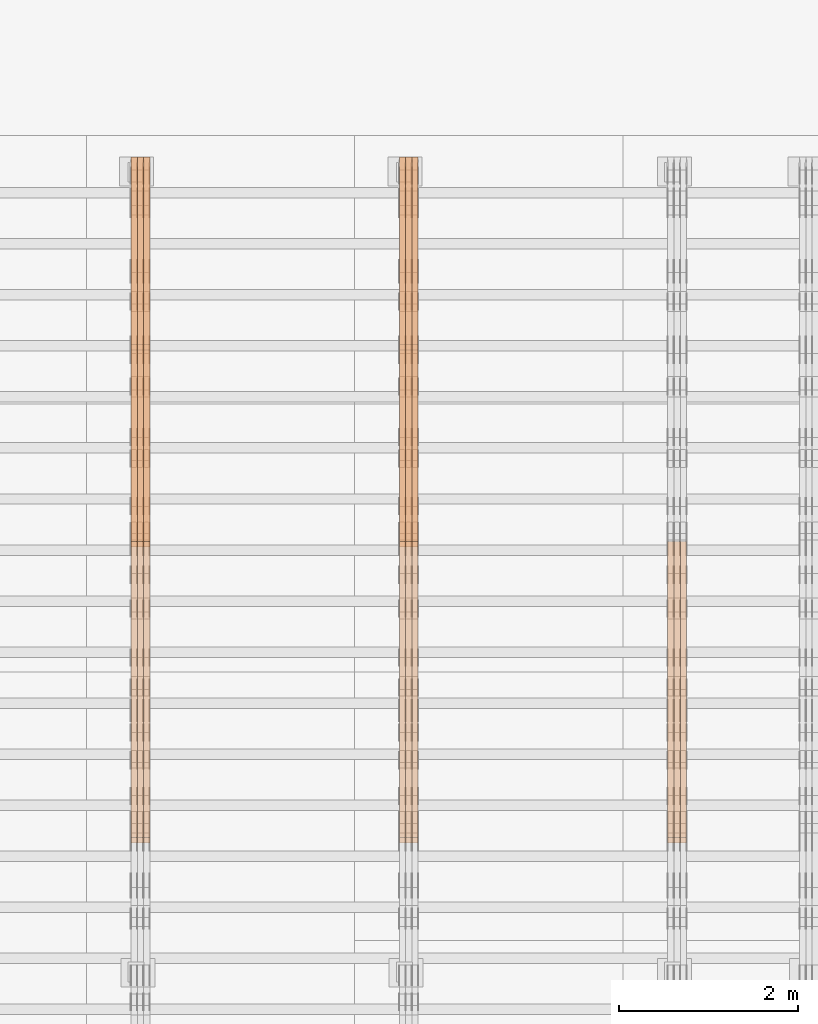
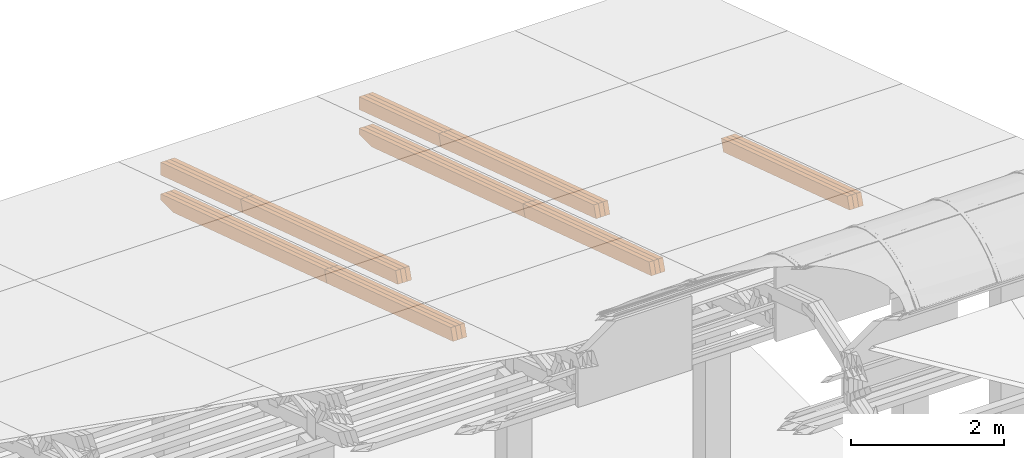
# One storey, part 31 of 385: 27 proxies.
"""IFC2X3 building model written with IfcOpenShell, lengths in millimetres."""

from ifc_helpers import new_model, entity, si_unit, converted_unit, derived_unit, direction, frame, origin, place, context, subcontext, project, spatial, polyline, outline, extrude, source, transform, mapped, material, type_object, type_shapes, element, save


model = new_model("IFC2X3")

# Units and contexts
model_context = context("Model", 3, precision=0.01, world=origin(), true_north=direction((6.12303176911189e-17, 1.0)))
body_context = subcontext(model_context, "Body", "Model", "MODEL_VIEW")
ifc_project = project(units=[si_unit("LENGTHUNIT", "METRE", prefix="MILLI"), si_unit("AREAUNIT", "SQUARE_METRE"), si_unit("VOLUMEUNIT", "CUBIC_METRE"), converted_unit("PLANEANGLEUNIT", "DEGREE", entity("IfcRatioMeasure", 0.0174532925199433), si_unit("PLANEANGLEUNIT", "RADIAN"), dimensions=[0, 0, 0, 0, 0, 0, 0]), si_unit("MASSUNIT", "GRAM", prefix="KILO"), derived_unit("MASSDENSITYUNIT", [(si_unit("MASSUNIT", "GRAM", prefix="KILO"), 1), (si_unit("LENGTHUNIT", "METRE"), -3)]), si_unit("TIMEUNIT", "SECOND"), si_unit("FREQUENCYUNIT", "HERTZ"), si_unit("THERMODYNAMICTEMPERATUREUNIT", "DEGREE_CELSIUS"), derived_unit("THERMALTRANSMITTANCEUNIT", [(si_unit("MASSUNIT", "GRAM", prefix="KILO"), 1), (si_unit("THERMODYNAMICTEMPERATUREUNIT", "KELVIN"), -1), (si_unit("TIMEUNIT", "SECOND"), -3)]), derived_unit("VOLUMETRICFLOWRATEUNIT", [(si_unit("LENGTHUNIT", "METRE"), 3), (si_unit("TIMEUNIT", "SECOND"), -1)]), si_unit("ELECTRICCURRENTUNIT", "AMPERE"), si_unit("ELECTRICVOLTAGEUNIT", "VOLT"), si_unit("POWERUNIT", "WATT"), si_unit("FORCEUNIT", "NEWTON", prefix="KILO"), si_unit("ILLUMINANCEUNIT", "LUX"), si_unit("LUMINOUSFLUXUNIT", "LUMEN"), si_unit("LUMINOUSINTENSITYUNIT", "CANDELA"), derived_unit("USERDEFINED", [(si_unit("MASSUNIT", "GRAM", prefix="KILO"), -1), (si_unit("LENGTHUNIT", "METRE"), -2), (si_unit("TIMEUNIT", "SECOND"), 3), (si_unit("LUMINOUSFLUXUNIT", "LUMEN"), 1)]), derived_unit("LINEARVELOCITYUNIT", [(si_unit("LENGTHUNIT", "METRE"), 1), (si_unit("TIMEUNIT", "SECOND"), -1)]), si_unit("PRESSUREUNIT", "PASCAL"), derived_unit("USERDEFINED", [(si_unit("LENGTHUNIT", "METRE"), -2), (si_unit("MASSUNIT", "GRAM", prefix="KILO"), 1), (si_unit("TIMEUNIT", "SECOND"), -2)])], contexts=[model_context])

# Site, building, storey
site_placement = place(None, origin())
site = spatial("IfcSite", under=ifc_project, at=site_placement, CompositionType="ELEMENT")
building_placement = place(site_placement, origin())
building = spatial("IfcBuilding", under=site, at=building_placement, CompositionType="ELEMENT")
storey_placement = place(building_placement, origin())
storey = spatial("IfcBuildingStorey", under=building, at=storey_placement, Name="Default", CompositionType="ELEMENT", Elevation=0.0)

# Proxies
ifc_material_1 = material(Name="IfcSurfaceStyle #557706")
building_element_proxy_type_1 = type_object("IfcBuildingElementProxyType", Name="T1-B2 557704", PredefinedType="NOTDEFINED", material=ifc_material_1)
shared_shape_1 = source(origin(), body_context, "Body", "SweptSolid", [
    extrude(outline(polyline([(-1738.61933402934, -97.4999466901035), (1738.6190788485, -97.4999466901035), (1738.6191018378, 97.4999466901035), (-1738.61884665697, 97.4999466901035), (-1738.61933402934, -97.4999466901035)])), frame((1738.6191018378, 97.4999528847471, 0.0), z_axis=(0.0, 0.0, 1.0), x_axis=(-1.0, 0.0, 0.0)), (0.0, 0.0, 1.0), 69.9999999999998),
])
type_shapes(building_element_proxy_type_1, [shared_shape_1])
proxy_1_placement = place(building_placement, frame((48385.0, 22140.4521465233, 1306.03026754604), z_axis=(-1.0, 0.0, 0.0), x_axis=(0.0, -0.951056516295124, 0.309016994375039)))
element("IfcBuildingElementProxy", 1, at=proxy_1_placement, inside=storey, type_object=building_element_proxy_type_1, material=ifc_material_1, Name="T1-B2", context=body_context, shape_type="MappedRepresentation", body=[
    mapped(shared_shape_1, transform((0.0, 0.0, 0.0), scale=1.0)),
])
ifc_material_2 = material(Name="IfcSurfaceStyle #557649")
building_element_proxy_type_2 = type_object("IfcBuildingElementProxyType", Name="T1-B2 557647", PredefinedType="NOTDEFINED", material=ifc_material_2)
shared_shape_2 = source(origin(), body_context, "Body", "SweptSolid", [
    extrude(outline(polyline([(-1738.61933402934, -97.4999466901035), (1738.6190788485, -97.4999466901035), (1738.6191018378, 97.4999466901035), (-1738.61884665697, 97.4999466901035), (-1738.61933402934, -97.4999466901035)])), frame((1738.6191018378, 97.4999528847471, 0.0), z_axis=(0.0, 0.0, 1.0), x_axis=(-1.0, 0.0, 0.0)), (0.0, 0.0, 1.0), 69.9999999999998),
])
type_shapes(building_element_proxy_type_2, [shared_shape_2])
proxy_2_placement = place(building_placement, frame((48315.0, 22140.4521465233, 1306.03026754604), z_axis=(-1.0, 0.0, 0.0), x_axis=(0.0, -0.951056516295124, 0.309016994375039)))
element("IfcBuildingElementProxy", 2, at=proxy_2_placement, inside=storey, type_object=building_element_proxy_type_2, material=ifc_material_2, Name="T1-B2", context=body_context, shape_type="MappedRepresentation", body=[
    mapped(shared_shape_2, transform((0.0, 0.0, 0.0), scale=1.0)),
])
ifc_material_3 = material(Name="IfcSurfaceStyle #557592")
building_element_proxy_type_3 = type_object("IfcBuildingElementProxyType", Name="T1-B2 557590", PredefinedType="NOTDEFINED", material=ifc_material_3)
shared_shape_3 = source(origin(), body_context, "Body", "SweptSolid", [
    extrude(outline(polyline([(-1738.61933402934, -97.4999466901035), (1738.6190788485, -97.4999466901035), (1738.6191018378, 97.4999466901035), (-1738.61884665697, 97.4999466901035), (-1738.61933402934, -97.4999466901035)])), frame((1738.6191018378, 97.4999528847471, 0.0), z_axis=(0.0, 0.0, 1.0), x_axis=(-1.0, 0.0, 0.0)), (0.0, 0.0, 1.0), 69.9999999999998),
])
type_shapes(building_element_proxy_type_3, [shared_shape_3])
proxy_3_placement = place(building_placement, frame((48245.0, 22140.4521465233, 1306.03026754604), z_axis=(-1.0, 0.0, 0.0), x_axis=(0.0, -0.951056516295124, 0.309016994375039)))
element("IfcBuildingElementProxy", 3, at=proxy_3_placement, inside=storey, type_object=building_element_proxy_type_3, material=ifc_material_3, Name="T1-B2", context=body_context, shape_type="MappedRepresentation", body=[
    mapped(shared_shape_3, transform((0.0, 0.0, 0.0), scale=1.0)),
])
ifc_material_4 = material(Name="IfcSurfaceStyle #524669")
building_element_proxy_type_4 = type_object("IfcBuildingElementProxyType", Name="T1-T2 524667", PredefinedType="NOTDEFINED", material=ifc_material_4)
shared_shape_4 = source(origin(), body_context, "Body", "SweptSolid", [
    extrude(outline(polyline([(-2137.04373183812, -97.5000250291418), (2137.04394104036, -97.5000250291418), (2137.04396402965, 97.5000250291418), (-2137.04417323189, 97.5000250291418), (-2137.04373183812, -97.5000250291418)])), frame((2137.04396402965, 97.5001541485632, 0.0), z_axis=(0.0, 0.0, 1.0), x_axis=(-1.0, 0.0, 0.0)), (0.0, 0.0, 1.0), 69.9999999999997),
])
type_shapes(building_element_proxy_type_4, [shared_shape_4])
proxy_4_placement = place(building_placement, frame((45385.0, 24344.7841397874, 1095.2368156767), z_axis=(-1.0, 0.0, 0.0), x_axis=(0.0, -0.951056516295154, 0.309016994374948)))
element("IfcBuildingElementProxy", 4, at=proxy_4_placement, inside=storey, type_object=building_element_proxy_type_4, material=ifc_material_4, Name="T1-T2", context=body_context, shape_type="MappedRepresentation", body=[
    mapped(shared_shape_4, transform((0.0, 0.0, 0.0), scale=1.0)),
])
ifc_material_5 = material(Name="IfcSurfaceStyle #524612")
building_element_proxy_type_5 = type_object("IfcBuildingElementProxyType", Name="T1-T2 524610", PredefinedType="NOTDEFINED", material=ifc_material_5)
shared_shape_5 = source(origin(), body_context, "Body", "SweptSolid", [
    extrude(outline(polyline([(-2137.04373183812, -97.5000250291418), (2137.04394104036, -97.5000250291418), (2137.04396402965, 97.5000250291418), (-2137.04417323189, 97.5000250291418), (-2137.04373183812, -97.5000250291418)])), frame((2137.04396402965, 97.5001541485632, 0.0), z_axis=(0.0, 0.0, 1.0), x_axis=(-1.0, 0.0, 0.0)), (0.0, 0.0, 1.0), 69.9999999999997),
])
type_shapes(building_element_proxy_type_5, [shared_shape_5])
proxy_5_placement = place(building_placement, frame((45315.0, 24344.7841397874, 1095.2368156767), z_axis=(-1.0, 0.0, 0.0), x_axis=(0.0, -0.951056516295154, 0.309016994374948)))
element("IfcBuildingElementProxy", 5, at=proxy_5_placement, inside=storey, type_object=building_element_proxy_type_5, material=ifc_material_5, Name="T1-T2", context=body_context, shape_type="MappedRepresentation", body=[
    mapped(shared_shape_5, transform((0.0, 0.0, 0.0), scale=1.0)),
])
ifc_material_6 = material(Name="IfcSurfaceStyle #524555")
building_element_proxy_type_6 = type_object("IfcBuildingElementProxyType", Name="T1-T2 524553", PredefinedType="NOTDEFINED", material=ifc_material_6)
shared_shape_6 = source(origin(), body_context, "Body", "SweptSolid", [
    extrude(outline(polyline([(-2137.04373183812, -97.5000250291418), (2137.04394104036, -97.5000250291418), (2137.04396402965, 97.5000250291418), (-2137.04417323189, 97.5000250291418), (-2137.04373183812, -97.5000250291418)])), frame((2137.04396402965, 97.5001541485632, 0.0), z_axis=(0.0, 0.0, 1.0), x_axis=(-1.0, 0.0, 0.0)), (0.0, 0.0, 1.0), 69.9999999999997),
])
type_shapes(building_element_proxy_type_6, [shared_shape_6])
proxy_6_placement = place(building_placement, frame((45245.0, 24344.7841397874, 1095.2368156767), z_axis=(-1.0, 0.0, 0.0), x_axis=(0.0, -0.951056516295154, 0.309016994374948)))
element("IfcBuildingElementProxy", 6, at=proxy_6_placement, inside=storey, type_object=building_element_proxy_type_6, material=ifc_material_6, Name="T1-T2", context=body_context, shape_type="MappedRepresentation", body=[
    mapped(shared_shape_6, transform((0.0, 0.0, 0.0), scale=1.0)),
])
ifc_material_7 = material(Name="IfcSurfaceStyle #524498")
building_element_proxy_type_7 = type_object("IfcBuildingElementProxyType", Name="T1-T3 524496", PredefinedType="NOTDEFINED", material=ifc_material_7)
shared_shape_7 = source(origin(), body_context, "Body", "SweptSolid", [
    extrude(outline(polyline([(-1117.22419189679, -97.5000115568039), (1085.54451125458, -97.5000115568039), (1148.90384954971, 97.5000115568039), (-1117.2241689075, 97.5000115568039), (-1117.22419189679, -97.5000115568039)])), frame((1148.90385201956, 97.5000191595882, 0.0), z_axis=(0.0, 0.0, 1.0), x_axis=(-1.0, 0.0, 0.0)), (0.0, 0.0, 1.0), 69.9999999999999),
])
type_shapes(building_element_proxy_type_7, [shared_shape_7])
proxy_7_placement = place(building_placement, frame((45385.0, 26500.0, 394.964866273674), z_axis=(-1.0, 0.0, 0.0), x_axis=(0.0, -0.951056516295154, 0.309016994374948)))
element("IfcBuildingElementProxy", 7, at=proxy_7_placement, inside=storey, type_object=building_element_proxy_type_7, material=ifc_material_7, Name="T1-T3", context=body_context, shape_type="MappedRepresentation", body=[
    mapped(shared_shape_7, transform((0.0, 0.0, 0.0), scale=1.0)),
])
ifc_material_8 = material(Name="IfcSurfaceStyle #524441")
building_element_proxy_type_8 = type_object("IfcBuildingElementProxyType", Name="T1-T3 524439", PredefinedType="NOTDEFINED", material=ifc_material_8)
shared_shape_8 = source(origin(), body_context, "Body", "SweptSolid", [
    extrude(outline(polyline([(-1117.22419189679, -97.5000115568039), (1085.54451125458, -97.5000115568039), (1148.90384954971, 97.5000115568039), (-1117.2241689075, 97.5000115568039), (-1117.22419189679, -97.5000115568039)])), frame((1148.90385201956, 97.5000191595882, 0.0), z_axis=(0.0, 0.0, 1.0), x_axis=(-1.0, 0.0, 0.0)), (0.0, 0.0, 1.0), 69.9999999999999),
])
type_shapes(building_element_proxy_type_8, [shared_shape_8])
proxy_8_placement = place(building_placement, frame((45315.0, 26500.0, 394.964866273674), z_axis=(-1.0, 0.0, 0.0), x_axis=(0.0, -0.951056516295154, 0.309016994374948)))
element("IfcBuildingElementProxy", 8, at=proxy_8_placement, inside=storey, type_object=building_element_proxy_type_8, material=ifc_material_8, Name="T1-T3", context=body_context, shape_type="MappedRepresentation", body=[
    mapped(shared_shape_8, transform((0.0, 0.0, 0.0), scale=1.0)),
])
ifc_material_9 = material(Name="IfcSurfaceStyle #524384")
building_element_proxy_type_9 = type_object("IfcBuildingElementProxyType", Name="T1-T3 524382", PredefinedType="NOTDEFINED", material=ifc_material_9)
shared_shape_9 = source(origin(), body_context, "Body", "SweptSolid", [
    extrude(outline(polyline([(-1117.22419189679, -97.5000115568039), (1085.54451125458, -97.5000115568039), (1148.90384954971, 97.5000115568039), (-1117.2241689075, 97.5000115568039), (-1117.22419189679, -97.5000115568039)])), frame((1148.90385201956, 97.5000191595882, 0.0), z_axis=(0.0, 0.0, 1.0), x_axis=(-1.0, 0.0, 0.0)), (0.0, 0.0, 1.0), 69.9999999999999),
])
type_shapes(building_element_proxy_type_9, [shared_shape_9])
proxy_9_placement = place(building_placement, frame((45245.0, 26500.0, 394.964866273674), z_axis=(-1.0, 0.0, 0.0), x_axis=(0.0, -0.951056516295154, 0.309016994374948)))
element("IfcBuildingElementProxy", 9, at=proxy_9_placement, inside=storey, type_object=building_element_proxy_type_9, material=ifc_material_9, Name="T1-T3", context=body_context, shape_type="MappedRepresentation", body=[
    mapped(shared_shape_9, transform((0.0, 0.0, 0.0), scale=1.0)),
])
ifc_material_10 = material(Name="IfcSurfaceStyle #523274")
building_element_proxy_type_10 = type_object("IfcBuildingElementProxyType", Name="T1-B2 523272", PredefinedType="NOTDEFINED", material=ifc_material_10)
shared_shape_10 = source(origin(), body_context, "Body", "SweptSolid", [
    extrude(outline(polyline([(-1738.61933402934, -97.4999466901035), (1738.6190788485, -97.4999466901035), (1738.6191018378, 97.4999466901035), (-1738.61884665697, 97.4999466901035), (-1738.61933402934, -97.4999466901035)])), frame((1738.6191018378, 97.4999528847471, 0.0), z_axis=(0.0, 0.0, 1.0), x_axis=(-1.0, 0.0, 0.0)), (0.0, 0.0, 1.0), 69.9999999999998),
])
type_shapes(building_element_proxy_type_10, [shared_shape_10])
proxy_10_placement = place(building_placement, frame((45385.0, 22140.4521465233, 1306.03026754604), z_axis=(-1.0, 0.0, 0.0), x_axis=(0.0, -0.951056516295124, 0.309016994375039)))
element("IfcBuildingElementProxy", 10, at=proxy_10_placement, inside=storey, type_object=building_element_proxy_type_10, material=ifc_material_10, Name="T1-B2", context=body_context, shape_type="MappedRepresentation", body=[
    mapped(shared_shape_10, transform((0.0, 0.0, 0.0), scale=1.0)),
])
ifc_material_11 = material(Name="IfcSurfaceStyle #523217")
building_element_proxy_type_11 = type_object("IfcBuildingElementProxyType", Name="T1-B2 523215", PredefinedType="NOTDEFINED", material=ifc_material_11)
shared_shape_11 = source(origin(), body_context, "Body", "SweptSolid", [
    extrude(outline(polyline([(-1738.61933402934, -97.4999466901035), (1738.6190788485, -97.4999466901035), (1738.6191018378, 97.4999466901035), (-1738.61884665697, 97.4999466901035), (-1738.61933402934, -97.4999466901035)])), frame((1738.6191018378, 97.4999528847471, 0.0), z_axis=(0.0, 0.0, 1.0), x_axis=(-1.0, 0.0, 0.0)), (0.0, 0.0, 1.0), 69.9999999999998),
])
type_shapes(building_element_proxy_type_11, [shared_shape_11])
proxy_11_placement = place(building_placement, frame((45315.0, 22140.4521465233, 1306.03026754604), z_axis=(-1.0, 0.0, 0.0), x_axis=(0.0, -0.951056516295124, 0.309016994375039)))
element("IfcBuildingElementProxy", 11, at=proxy_11_placement, inside=storey, type_object=building_element_proxy_type_11, material=ifc_material_11, Name="T1-B2", context=body_context, shape_type="MappedRepresentation", body=[
    mapped(shared_shape_11, transform((0.0, 0.0, 0.0), scale=1.0)),
])
ifc_material_12 = material(Name="IfcSurfaceStyle #523160")
building_element_proxy_type_12 = type_object("IfcBuildingElementProxyType", Name="T1-B2 523158", PredefinedType="NOTDEFINED", material=ifc_material_12)
shared_shape_12 = source(origin(), body_context, "Body", "SweptSolid", [
    extrude(outline(polyline([(-1738.61933402934, -97.4999466901035), (1738.6190788485, -97.4999466901035), (1738.6191018378, 97.4999466901035), (-1738.61884665697, 97.4999466901035), (-1738.61933402934, -97.4999466901035)])), frame((1738.6191018378, 97.4999528847471, 0.0), z_axis=(0.0, 0.0, 1.0), x_axis=(-1.0, 0.0, 0.0)), (0.0, 0.0, 1.0), 69.9999999999998),
])
type_shapes(building_element_proxy_type_12, [shared_shape_12])
proxy_12_placement = place(building_placement, frame((45245.0, 22140.4521465233, 1306.03026754604), z_axis=(-1.0, 0.0, 0.0), x_axis=(0.0, -0.951056516295124, 0.309016994375039)))
element("IfcBuildingElementProxy", 12, at=proxy_12_placement, inside=storey, type_object=building_element_proxy_type_12, material=ifc_material_12, Name="T1-B2", context=body_context, shape_type="MappedRepresentation", body=[
    mapped(shared_shape_12, transform((0.0, 0.0, 0.0), scale=1.0)),
])
ifc_material_13 = material(Name="IfcSurfaceStyle #523103")
building_element_proxy_type_13 = type_object("IfcBuildingElementProxyType", Name="T1-B1 523101", PredefinedType="NOTDEFINED", material=ifc_material_13)
shared_shape_13 = source(origin(), body_context, "Body", "SweptSolid", [
    extrude(outline(polyline([(-2659.34106034305, -95.9868650736445), (1861.19950396595, -95.9868650736445), (1890.42090463564, -6.05260867570997), (1567.0616890952, 99.0131694114995), (-2659.34103735375, 99.0131694114995), (-2659.34106034305, -95.9868650736445)])), frame((1890.42090463564, 99.013169411504, 0.0), z_axis=(0.0, 0.0, 1.0), x_axis=(-1.0, 0.0, 0.0)), (0.0, 0.0, 1.0), 69.9999999999997),
])
type_shapes(building_element_proxy_type_13, [shared_shape_13])
proxy_13_placement = place(building_placement, frame((45385.0, 26467.5328890438, -99.9234928894624), z_axis=(-1.0, 0.0, 0.0), x_axis=(0.0, -0.951056516295124, 0.309016994375039)))
element("IfcBuildingElementProxy", 13, at=proxy_13_placement, inside=storey, type_object=building_element_proxy_type_13, material=ifc_material_13, Name="T1-B1", context=body_context, shape_type="MappedRepresentation", body=[
    mapped(shared_shape_13, transform((0.0, 0.0, 0.0), scale=1.0)),
])
ifc_material_14 = material(Name="IfcSurfaceStyle #523037")
building_element_proxy_type_14 = type_object("IfcBuildingElementProxyType", Name="T1-B1 523035", PredefinedType="NOTDEFINED", material=ifc_material_14)
shared_shape_14 = source(origin(), body_context, "Body", "SweptSolid", [
    extrude(outline(polyline([(-2659.34106034305, -95.9868650736445), (1861.19950396595, -95.9868650736445), (1890.42090463564, -6.05260867570997), (1567.0616890952, 99.0131694114995), (-2659.34103735375, 99.0131694114995), (-2659.34106034305, -95.9868650736445)])), frame((1890.42090463564, 99.013169411504, 0.0), z_axis=(0.0, 0.0, 1.0), x_axis=(-1.0, 0.0, 0.0)), (0.0, 0.0, 1.0), 69.9999999999997),
])
type_shapes(building_element_proxy_type_14, [shared_shape_14])
proxy_14_placement = place(building_placement, frame((45315.0, 26467.5328890438, -99.9234928894624), z_axis=(-1.0, 0.0, 0.0), x_axis=(0.0, -0.951056516295124, 0.309016994375039)))
element("IfcBuildingElementProxy", 14, at=proxy_14_placement, inside=storey, type_object=building_element_proxy_type_14, material=ifc_material_14, Name="T1-B1", context=body_context, shape_type="MappedRepresentation", body=[
    mapped(shared_shape_14, transform((0.0, 0.0, 0.0), scale=1.0)),
])
ifc_material_15 = material(Name="IfcSurfaceStyle #522971")
building_element_proxy_type_15 = type_object("IfcBuildingElementProxyType", Name="T1-B1 522969", PredefinedType="NOTDEFINED", material=ifc_material_15)
shared_shape_15 = source(origin(), body_context, "Body", "SweptSolid", [
    extrude(outline(polyline([(-2659.34106034305, -95.9868650736445), (1861.19950396595, -95.9868650736445), (1890.42090463564, -6.05260867570997), (1567.0616890952, 99.0131694114995), (-2659.34103735375, 99.0131694114995), (-2659.34106034305, -95.9868650736445)])), frame((1890.42090463564, 99.013169411504, 0.0), z_axis=(0.0, 0.0, 1.0), x_axis=(-1.0, 0.0, 0.0)), (0.0, 0.0, 1.0), 69.9999999999997),
])
type_shapes(building_element_proxy_type_15, [shared_shape_15])
proxy_15_placement = place(building_placement, frame((45245.0, 26467.5328890438, -99.9234928894624), z_axis=(-1.0, 0.0, 0.0), x_axis=(0.0, -0.951056516295124, 0.309016994375039)))
element("IfcBuildingElementProxy", 15, at=proxy_15_placement, inside=storey, type_object=building_element_proxy_type_15, material=ifc_material_15, Name="T1-B1", context=body_context, shape_type="MappedRepresentation", body=[
    mapped(shared_shape_15, transform((0.0, 0.0, 0.0), scale=1.0)),
])
ifc_material_16 = material(Name="IfcSurfaceStyle #490237")
building_element_proxy_type_16 = type_object("IfcBuildingElementProxyType", Name="T1-T2 490235", PredefinedType="NOTDEFINED", material=ifc_material_16)
shared_shape_16 = source(origin(), body_context, "Body", "SweptSolid", [
    extrude(outline(polyline([(-2137.04373183812, -97.5000250291418), (2137.04394104036, -97.5000250291418), (2137.04396402965, 97.5000250291418), (-2137.04417323189, 97.5000250291418), (-2137.04373183812, -97.5000250291418)])), frame((2137.04396402965, 97.5001541485632, 0.0), z_axis=(0.0, 0.0, 1.0), x_axis=(-1.0, 0.0, 0.0)), (0.0, 0.0, 1.0), 69.9999999999997),
])
type_shapes(building_element_proxy_type_16, [shared_shape_16])
proxy_16_placement = place(building_placement, frame((42385.0, 24344.7841397874, 1095.2368156767), z_axis=(-1.0, 0.0, 0.0), x_axis=(0.0, -0.951056516295154, 0.309016994374948)))
element("IfcBuildingElementProxy", 16, at=proxy_16_placement, inside=storey, type_object=building_element_proxy_type_16, material=ifc_material_16, Name="T1-T2", context=body_context, shape_type="MappedRepresentation", body=[
    mapped(shared_shape_16, transform((0.0, 0.0, 0.0), scale=1.0)),
])
ifc_material_17 = material(Name="IfcSurfaceStyle #490180")
building_element_proxy_type_17 = type_object("IfcBuildingElementProxyType", Name="T1-T2 490178", PredefinedType="NOTDEFINED", material=ifc_material_17)
shared_shape_17 = source(origin(), body_context, "Body", "SweptSolid", [
    extrude(outline(polyline([(-2137.04373183812, -97.5000250291418), (2137.04394104036, -97.5000250291418), (2137.04396402965, 97.5000250291418), (-2137.04417323189, 97.5000250291418), (-2137.04373183812, -97.5000250291418)])), frame((2137.04396402965, 97.5001541485632, 0.0), z_axis=(0.0, 0.0, 1.0), x_axis=(-1.0, 0.0, 0.0)), (0.0, 0.0, 1.0), 69.9999999999997),
])
type_shapes(building_element_proxy_type_17, [shared_shape_17])
proxy_17_placement = place(building_placement, frame((42315.0, 24344.7841397874, 1095.2368156767), z_axis=(-1.0, 0.0, 0.0), x_axis=(0.0, -0.951056516295154, 0.309016994374948)))
element("IfcBuildingElementProxy", 17, at=proxy_17_placement, inside=storey, type_object=building_element_proxy_type_17, material=ifc_material_17, Name="T1-T2", context=body_context, shape_type="MappedRepresentation", body=[
    mapped(shared_shape_17, transform((0.0, 0.0, 0.0), scale=1.0)),
])
ifc_material_18 = material(Name="IfcSurfaceStyle #490123")
building_element_proxy_type_18 = type_object("IfcBuildingElementProxyType", Name="T1-T2 490121", PredefinedType="NOTDEFINED", material=ifc_material_18)
shared_shape_18 = source(origin(), body_context, "Body", "SweptSolid", [
    extrude(outline(polyline([(-2137.04373183812, -97.5000250291418), (2137.04394104036, -97.5000250291418), (2137.04396402965, 97.5000250291418), (-2137.04417323189, 97.5000250291418), (-2137.04373183812, -97.5000250291418)])), frame((2137.04396402965, 97.5001541485632, 0.0), z_axis=(0.0, 0.0, 1.0), x_axis=(-1.0, 0.0, 0.0)), (0.0, 0.0, 1.0), 69.9999999999997),
])
type_shapes(building_element_proxy_type_18, [shared_shape_18])
proxy_18_placement = place(building_placement, frame((42245.0, 24344.7841397874, 1095.2368156767), z_axis=(-1.0, 0.0, 0.0), x_axis=(0.0, -0.951056516295154, 0.309016994374948)))
element("IfcBuildingElementProxy", 18, at=proxy_18_placement, inside=storey, type_object=building_element_proxy_type_18, material=ifc_material_18, Name="T1-T2", context=body_context, shape_type="MappedRepresentation", body=[
    mapped(shared_shape_18, transform((0.0, 0.0, 0.0), scale=1.0)),
])
ifc_material_19 = material(Name="IfcSurfaceStyle #490066")
building_element_proxy_type_19 = type_object("IfcBuildingElementProxyType", Name="T1-T3 490064", PredefinedType="NOTDEFINED", material=ifc_material_19)
shared_shape_19 = source(origin(), body_context, "Body", "SweptSolid", [
    extrude(outline(polyline([(-1117.22419189679, -97.5000115568039), (1085.54451125458, -97.5000115568039), (1148.90384954971, 97.5000115568039), (-1117.2241689075, 97.5000115568039), (-1117.22419189679, -97.5000115568039)])), frame((1148.90385201956, 97.5000191595882, 0.0), z_axis=(0.0, 0.0, 1.0), x_axis=(-1.0, 0.0, 0.0)), (0.0, 0.0, 1.0), 69.9999999999999),
])
type_shapes(building_element_proxy_type_19, [shared_shape_19])
proxy_19_placement = place(building_placement, frame((42385.0, 26500.0, 394.964866273674), z_axis=(-1.0, 0.0, 0.0), x_axis=(0.0, -0.951056516295154, 0.309016994374948)))
element("IfcBuildingElementProxy", 19, at=proxy_19_placement, inside=storey, type_object=building_element_proxy_type_19, material=ifc_material_19, Name="T1-T3", context=body_context, shape_type="MappedRepresentation", body=[
    mapped(shared_shape_19, transform((0.0, 0.0, 0.0), scale=1.0)),
])
ifc_material_20 = material(Name="IfcSurfaceStyle #490009")
building_element_proxy_type_20 = type_object("IfcBuildingElementProxyType", Name="T1-T3 490007", PredefinedType="NOTDEFINED", material=ifc_material_20)
shared_shape_20 = source(origin(), body_context, "Body", "SweptSolid", [
    extrude(outline(polyline([(-1117.22419189679, -97.5000115568039), (1085.54451125458, -97.5000115568039), (1148.90384954971, 97.5000115568039), (-1117.2241689075, 97.5000115568039), (-1117.22419189679, -97.5000115568039)])), frame((1148.90385201956, 97.5000191595882, 0.0), z_axis=(0.0, 0.0, 1.0), x_axis=(-1.0, 0.0, 0.0)), (0.0, 0.0, 1.0), 69.9999999999999),
])
type_shapes(building_element_proxy_type_20, [shared_shape_20])
proxy_20_placement = place(building_placement, frame((42315.0, 26500.0, 394.964866273674), z_axis=(-1.0, 0.0, 0.0), x_axis=(0.0, -0.951056516295154, 0.309016994374948)))
element("IfcBuildingElementProxy", 20, at=proxy_20_placement, inside=storey, type_object=building_element_proxy_type_20, material=ifc_material_20, Name="T1-T3", context=body_context, shape_type="MappedRepresentation", body=[
    mapped(shared_shape_20, transform((0.0, 0.0, 0.0), scale=1.0)),
])
ifc_material_21 = material(Name="IfcSurfaceStyle #489952")
building_element_proxy_type_21 = type_object("IfcBuildingElementProxyType", Name="T1-T3 489950", PredefinedType="NOTDEFINED", material=ifc_material_21)
shared_shape_21 = source(origin(), body_context, "Body", "SweptSolid", [
    extrude(outline(polyline([(-1117.22419189679, -97.5000115568039), (1085.54451125458, -97.5000115568039), (1148.90384954971, 97.5000115568039), (-1117.2241689075, 97.5000115568039), (-1117.22419189679, -97.5000115568039)])), frame((1148.90385201956, 97.5000191595882, 0.0), z_axis=(0.0, 0.0, 1.0), x_axis=(-1.0, 0.0, 0.0)), (0.0, 0.0, 1.0), 69.9999999999999),
])
type_shapes(building_element_proxy_type_21, [shared_shape_21])
proxy_21_placement = place(building_placement, frame((42245.0, 26500.0, 394.964866273674), z_axis=(-1.0, 0.0, 0.0), x_axis=(0.0, -0.951056516295154, 0.309016994374948)))
element("IfcBuildingElementProxy", 21, at=proxy_21_placement, inside=storey, type_object=building_element_proxy_type_21, material=ifc_material_21, Name="T1-T3", context=body_context, shape_type="MappedRepresentation", body=[
    mapped(shared_shape_21, transform((0.0, 0.0, 0.0), scale=1.0)),
])
ifc_material_22 = material(Name="IfcSurfaceStyle #488842")
building_element_proxy_type_22 = type_object("IfcBuildingElementProxyType", Name="T1-B2 488840", PredefinedType="NOTDEFINED", material=ifc_material_22)
shared_shape_22 = source(origin(), body_context, "Body", "SweptSolid", [
    extrude(outline(polyline([(-1738.61933402934, -97.4999466901035), (1738.6190788485, -97.4999466901035), (1738.6191018378, 97.4999466901035), (-1738.61884665697, 97.4999466901035), (-1738.61933402934, -97.4999466901035)])), frame((1738.6191018378, 97.4999528847471, 0.0), z_axis=(0.0, 0.0, 1.0), x_axis=(-1.0, 0.0, 0.0)), (0.0, 0.0, 1.0), 69.9999999999998),
])
type_shapes(building_element_proxy_type_22, [shared_shape_22])
proxy_22_placement = place(building_placement, frame((42385.0, 22140.4521465233, 1306.03026754604), z_axis=(-1.0, 0.0, 0.0), x_axis=(0.0, -0.951056516295124, 0.309016994375039)))
element("IfcBuildingElementProxy", 22, at=proxy_22_placement, inside=storey, type_object=building_element_proxy_type_22, material=ifc_material_22, Name="T1-B2", context=body_context, shape_type="MappedRepresentation", body=[
    mapped(shared_shape_22, transform((0.0, 0.0, 0.0), scale=1.0)),
])
ifc_material_23 = material(Name="IfcSurfaceStyle #488785")
building_element_proxy_type_23 = type_object("IfcBuildingElementProxyType", Name="T1-B2 488783", PredefinedType="NOTDEFINED", material=ifc_material_23)
shared_shape_23 = source(origin(), body_context, "Body", "SweptSolid", [
    extrude(outline(polyline([(-1738.61933402934, -97.4999466901035), (1738.6190788485, -97.4999466901035), (1738.6191018378, 97.4999466901035), (-1738.61884665697, 97.4999466901035), (-1738.61933402934, -97.4999466901035)])), frame((1738.6191018378, 97.4999528847471, 0.0), z_axis=(0.0, 0.0, 1.0), x_axis=(-1.0, 0.0, 0.0)), (0.0, 0.0, 1.0), 69.9999999999998),
])
type_shapes(building_element_proxy_type_23, [shared_shape_23])
proxy_23_placement = place(building_placement, frame((42315.0, 22140.4521465233, 1306.03026754604), z_axis=(-1.0, 0.0, 0.0), x_axis=(0.0, -0.951056516295124, 0.309016994375039)))
element("IfcBuildingElementProxy", 23, at=proxy_23_placement, inside=storey, type_object=building_element_proxy_type_23, material=ifc_material_23, Name="T1-B2", context=body_context, shape_type="MappedRepresentation", body=[
    mapped(shared_shape_23, transform((0.0, 0.0, 0.0), scale=1.0)),
])
ifc_material_24 = material(Name="IfcSurfaceStyle #488728")
building_element_proxy_type_24 = type_object("IfcBuildingElementProxyType", Name="T1-B2 488726", PredefinedType="NOTDEFINED", material=ifc_material_24)
shared_shape_24 = source(origin(), body_context, "Body", "SweptSolid", [
    extrude(outline(polyline([(-1738.61933402934, -97.4999466901035), (1738.6190788485, -97.4999466901035), (1738.6191018378, 97.4999466901035), (-1738.61884665697, 97.4999466901035), (-1738.61933402934, -97.4999466901035)])), frame((1738.6191018378, 97.4999528847471, 0.0), z_axis=(0.0, 0.0, 1.0), x_axis=(-1.0, 0.0, 0.0)), (0.0, 0.0, 1.0), 69.9999999999998),
])
type_shapes(building_element_proxy_type_24, [shared_shape_24])
proxy_24_placement = place(building_placement, frame((42245.0, 22140.4521465233, 1306.03026754604), z_axis=(-1.0, 0.0, 0.0), x_axis=(0.0, -0.951056516295124, 0.309016994375039)))
element("IfcBuildingElementProxy", 24, at=proxy_24_placement, inside=storey, type_object=building_element_proxy_type_24, material=ifc_material_24, Name="T1-B2", context=body_context, shape_type="MappedRepresentation", body=[
    mapped(shared_shape_24, transform((0.0, 0.0, 0.0), scale=1.0)),
])
ifc_material_25 = material(Name="IfcSurfaceStyle #488671")
building_element_proxy_type_25 = type_object("IfcBuildingElementProxyType", Name="T1-B1 488669", PredefinedType="NOTDEFINED", material=ifc_material_25)
shared_shape_25 = source(origin(), body_context, "Body", "SweptSolid", [
    extrude(outline(polyline([(-2659.34106034305, -95.9868650736445), (1861.19950396595, -95.9868650736445), (1890.42090463564, -6.05260867570997), (1567.0616890952, 99.0131694114995), (-2659.34103735375, 99.0131694114995), (-2659.34106034305, -95.9868650736445)])), frame((1890.42090463564, 99.013169411504, 0.0), z_axis=(0.0, 0.0, 1.0), x_axis=(-1.0, 0.0, 0.0)), (0.0, 0.0, 1.0), 69.9999999999997),
])
type_shapes(building_element_proxy_type_25, [shared_shape_25])
proxy_25_placement = place(building_placement, frame((42385.0, 26467.5328890438, -99.9234928894624), z_axis=(-1.0, 0.0, 0.0), x_axis=(0.0, -0.951056516295124, 0.309016994375039)))
element("IfcBuildingElementProxy", 25, at=proxy_25_placement, inside=storey, type_object=building_element_proxy_type_25, material=ifc_material_25, Name="T1-B1", context=body_context, shape_type="MappedRepresentation", body=[
    mapped(shared_shape_25, transform((0.0, 0.0, 0.0), scale=1.0)),
])
ifc_material_26 = material(Name="IfcSurfaceStyle #488605")
building_element_proxy_type_26 = type_object("IfcBuildingElementProxyType", Name="T1-B1 488603", PredefinedType="NOTDEFINED", material=ifc_material_26)
shared_shape_26 = source(origin(), body_context, "Body", "SweptSolid", [
    extrude(outline(polyline([(-2659.34106034305, -95.9868650736445), (1861.19950396595, -95.9868650736445), (1890.42090463564, -6.05260867570997), (1567.0616890952, 99.0131694114995), (-2659.34103735375, 99.0131694114995), (-2659.34106034305, -95.9868650736445)])), frame((1890.42090463564, 99.013169411504, 0.0), z_axis=(0.0, 0.0, 1.0), x_axis=(-1.0, 0.0, 0.0)), (0.0, 0.0, 1.0), 69.9999999999997),
])
type_shapes(building_element_proxy_type_26, [shared_shape_26])
proxy_26_placement = place(building_placement, frame((42315.0, 26467.5328890438, -99.9234928894624), z_axis=(-1.0, 0.0, 0.0), x_axis=(0.0, -0.951056516295124, 0.309016994375039)))
element("IfcBuildingElementProxy", 26, at=proxy_26_placement, inside=storey, type_object=building_element_proxy_type_26, material=ifc_material_26, Name="T1-B1", context=body_context, shape_type="MappedRepresentation", body=[
    mapped(shared_shape_26, transform((0.0, 0.0, 0.0), scale=1.0)),
])
ifc_material_27 = material(Name="IfcSurfaceStyle #488539")
building_element_proxy_type_27 = type_object("IfcBuildingElementProxyType", Name="T1-B1 488537", PredefinedType="NOTDEFINED", material=ifc_material_27)
shared_shape_27 = source(origin(), body_context, "Body", "SweptSolid", [
    extrude(outline(polyline([(-2659.34106034305, -95.9868650736445), (1861.19950396595, -95.9868650736445), (1890.42090463564, -6.05260867570997), (1567.0616890952, 99.0131694114995), (-2659.34103735375, 99.0131694114995), (-2659.34106034305, -95.9868650736445)])), frame((1890.42090463564, 99.013169411504, 0.0), z_axis=(0.0, 0.0, 1.0), x_axis=(-1.0, 0.0, 0.0)), (0.0, 0.0, 1.0), 69.9999999999997),
])
type_shapes(building_element_proxy_type_27, [shared_shape_27])
proxy_27_placement = place(building_placement, frame((42245.0, 26467.5328890438, -99.9234928894624), z_axis=(-1.0, 0.0, 0.0), x_axis=(0.0, -0.951056516295124, 0.309016994375039)))
element("IfcBuildingElementProxy", 27, at=proxy_27_placement, inside=storey, type_object=building_element_proxy_type_27, material=ifc_material_27, Name="T1-B1", context=body_context, shape_type="MappedRepresentation", body=[
    mapped(shared_shape_27, transform((0.0, 0.0, 0.0), scale=1.0)),
])

save(model, "model.ifc")
